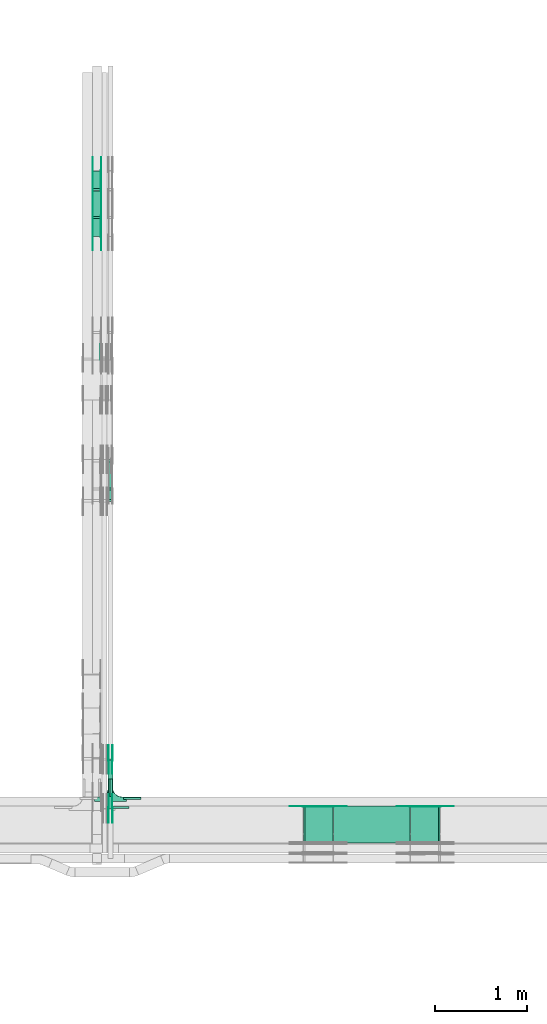
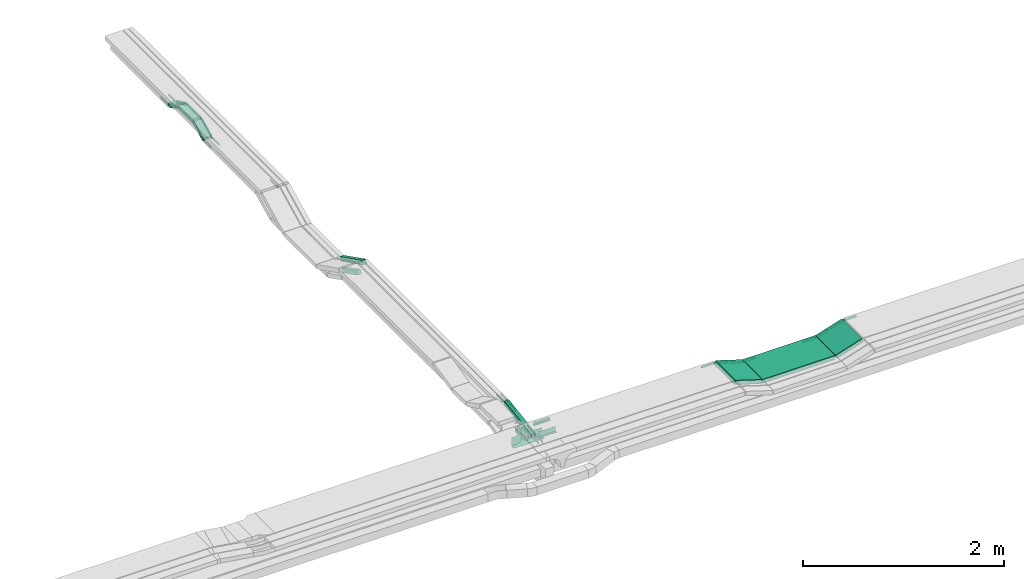
# One storey, part 19 of 27: 38 flow fittings, 9 flow segments.
"""IFC2X3 building model written with IfcOpenShell, lengths in millimetres."""

import ifcopenshell
import ifcopenshell.guid

model = None  # the IFC model being written
_history = None  # IfcOwnerHistory: only IFC2X3 demands one
_inside = {}  # id of a spatial element -> (the spatial element, [elements in it])
_under = {}  # id of a project, library or spatial element -> (it, [spatial elements below it])
_declared = {}  # id of a project -> (the project, [libraries it declares])
_typed = {}  # id of a type object -> (the type object, [elements of that type])
_made_of = {}  # id of a material, layer set ... -> (it, [elements and type objects made of it])


def new_model(schema):
    """Start an empty IFC model of exactly this schema.

    Asked for "IFC4X3", IfcOpenShell would pick the latest addendum, in which some entities
    have other attributes; the version numbers below select the first issue.
    IFC2X3 requires an IfcOwnerHistory on every rooted entity: one is made here for all.
    """
    global model, _history
    if schema == "IFC4X3":
        model = ifcopenshell.file(schema_version=(4, 3, 0, 0))
    else:
        model = ifcopenshell.file(schema=schema)
    _inside.clear()
    _under.clear()
    _declared.clear()
    _typed.clear()
    _made_of.clear()
    _history = None
    if model.schema == "IFC2X3":
        org = make("IfcOrganization", Name="unknown")
        user = make(
            "IfcPersonAndOrganization",
            ThePerson=make("IfcPerson", FamilyName="unknown"),
            TheOrganization=org,
        )
        app = make(
            "IfcApplication",
            ApplicationDeveloper=org,
            Version="unknown",
            ApplicationFullName="unknown",
            ApplicationIdentifier="unknown",
        )
        _history = make(
            "IfcOwnerHistory",
            OwningUser=user,
            OwningApplication=app,
            ChangeAction="ADDED",
            CreationDate=0,
        )
    return model


def make(cls, **values):
    """One entity of the class cls with the attributes given. An attribute that is None is left unset."""
    return model.create_entity(
        cls, **{name: value for name, value in values.items() if value is not None}
    )


def entity(cls, *values):
    """Any entity or typed value of the class cls, its attributes in the order of the schema. None: left unset."""
    e = model.create_entity(cls)
    for i, value in enumerate(values):
        if value is not None:
            e[i] = value
    return e


def rooted(cls, **values):
    """An entity with a GlobalId (a new one), such as an element, a storey or a relation."""
    return make(cls, GlobalId=ifcopenshell.guid.new(), OwnerHistory=_history, **values)


def si_unit(unit_type, name, prefix=None):
    """IfcSIUnit, for example si_unit("LENGTHUNIT", "METRE", prefix="MILLI")."""
    return make("IfcSIUnit", UnitType=unit_type, Prefix=prefix, Name=name)


def converted_unit(unit_type, name, factor, base, dimensions=None, offset=None):
    """IfcConversionBasedUnit, such as the inch: factor (a typed value) times the base unit."""
    return make(
        "IfcConversionBasedUnit"
        if offset is None
        else "IfcConversionBasedUnitWithOffset",
        ConversionOffset=offset,
        Dimensions=None
        if dimensions is None
        else entity("IfcDimensionalExponents", *dimensions),
        UnitType=unit_type,
        Name=name,
        ConversionFactor=make(
            "IfcMeasureWithUnit", ValueComponent=factor, UnitComponent=base
        ),
    )


def derived_unit(unit_type, elements):
    """IfcDerivedUnit: a product of units, each with its exponent."""
    return make(
        "IfcDerivedUnit",
        Elements=[
            make("IfcDerivedUnitElement", Unit=unit, Exponent=power)
            for unit, power in elements
        ],
        UnitType=unit_type,
    )


def assignment(units):
    """IfcUnitAssignment: the units of a project."""
    return None if units is None else make("IfcUnitAssignment", Units=units)


def point(xyz):
    """IfcCartesianPoint."""
    return None if xyz is None else make("IfcCartesianPoint", Coordinates=xyz)


def direction(xyz):
    """IfcDirection."""
    return None if xyz is None else make("IfcDirection", DirectionRatios=xyz)


def frame(location, z_axis=None, x_axis=None):
    """IfcAxis2Placement3D, a coordinate frame: its origin and axes. An axis left out is left unset."""
    return make(
        "IfcAxis2Placement3D",
        Location=point(location),
        Axis=direction(z_axis),
        RefDirection=direction(x_axis),
    )


def frame_2d(location, x_axis=None):
    """IfcAxis2Placement2D, a coordinate frame in the plane: its origin and x axis."""
    return make(
        "IfcAxis2Placement2D", Location=point(location), RefDirection=direction(x_axis)
    )


def origin():
    """The frame at (0, 0, 0) with its axes left unset."""
    return frame((0.0, 0.0, 0.0))


def origin_2d_with_axis():
    """The frame at (0, 0) in the plane with the x axis (1, 0) written out."""
    return frame_2d((0.0, 0.0), x_axis=(1.0, 0.0))


def place(relative_to, where):
    """IfcLocalPlacement: puts the frame where relative to a parent placement (None: the world)."""
    return make(
        "IfcLocalPlacement", PlacementRelTo=relative_to, RelativePlacement=where
    )


def context(
    kind, dimensions, precision=None, world=None, true_north=None, identifier=None
):
    """IfcGeometricRepresentationContext, for example the 3D "Model" context."""
    return make(
        "IfcGeometricRepresentationContext",
        ContextIdentifier=identifier,
        ContextType=kind,
        CoordinateSpaceDimension=dimensions,
        Precision=precision,
        WorldCoordinateSystem=world,
        TrueNorth=true_north,
    )


def subcontext(parent, identifier, kind, view, scale=None):
    """IfcGeometricRepresentationSubContext, for example "Body" below "Model"."""
    return make(
        "IfcGeometricRepresentationSubContext",
        ContextIdentifier=identifier,
        ContextType=kind,
        ParentContext=parent,
        TargetScale=scale,
        TargetView=view,
    )


def project(units=None, contexts=None):
    """IfcProject with its units and contexts."""
    return rooted(
        "IfcProject",
        Name="project",
        RepresentationContexts=contexts,
        UnitsInContext=assignment(units),
    )


def spatial(cls, under=None, at=None, **own):
    """A site, building, storey or space (cls), placed at a placement, below another one or the project."""
    s = rooted(cls, ObjectPlacement=at, **own)
    if under is not None:
        _under.setdefault(under.id(), (under, []))[1].append(s)
    return s


def polyline(points):
    """IfcPolyline through the points."""
    return make("IfcPolyline", Points=[point(p) for p in points])


def circle_curve(where, radius):
    """IfcCircle in the frame where."""
    return make("IfcCircle", Position=where, Radius=radius)


def parameter(value):
    """IfcParameterValue: where a trimmed curve begins or ends, as a parameter of its basis curve."""
    return model.create_entity("IfcParameterValue", value)


def trimmed(basis, trim1, trim2, sense, master):
    """IfcTrimmedCurve: the piece of a basis curve between two trims."""
    return make(
        "IfcTrimmedCurve",
        BasisCurve=basis,
        Trim1=trim1,
        Trim2=trim2,
        SenseAgreement=sense,
        MasterRepresentation=master,
    )


def segment(curve, same_sense, transition):
    """IfcCompositeCurveSegment."""
    return make(
        "IfcCompositeCurveSegment",
        Transition=transition,
        SameSense=same_sense,
        ParentCurve=curve,
    )


def composite_curve(segments, self_intersect=None):
    """IfcCompositeCurve: segments joined end to end."""
    return make("IfcCompositeCurve", Segments=segments, SelfIntersect=self_intersect)


def profile(cls, at=None, kind="AREA", **sizes):
    """A parametric profile (cls). Its sizes go by their IFC names, for example OverallWidth=200.0."""
    return make(cls, ProfileType=kind, Position=at, **sizes)


def rectangle(**sizes):
    """IfcRectangleProfileDef."""
    return profile("IfcRectangleProfileDef", **sizes)


def outline(outer, holes=None, kind="AREA"):
    """IfcArbitraryClosedProfileDef: a profile drawn as a closed curve; with holes, ...WithVoids."""
    if holes is None:
        return make("IfcArbitraryClosedProfileDef", ProfileType=kind, OuterCurve=outer)
    return make(
        "IfcArbitraryProfileDefWithVoids",
        ProfileType=kind,
        OuterCurve=outer,
        InnerCurves=holes,
    )


def extrude(swept, where, along, depth):
    """IfcExtrudedAreaSolid: the profile swept, set in the frame where, extruded along a direction by depth."""
    return make(
        "IfcExtrudedAreaSolid",
        SweptArea=swept,
        Position=where,
        ExtrudedDirection=direction(along),
        Depth=depth,
    )


def faces_of(points, faces, orient=None, outer=None):
    """IfcFace entities. A face is a list of loops; a loop is a list of indices into points, from 0.

    orient and outer hold one flag for each loop. By default every Orientation is true, the
    first loop of a face is its IfcFaceOuterBound and the others are IfcFaceBound.
    """
    made = []
    for i, loops in enumerate(faces):
        bounds = []
        for j, loop in enumerate(loops):
            is_outer = j == 0 if outer is None else outer[i][j]
            bounds.append(
                make(
                    "IfcFaceOuterBound" if is_outer else "IfcFaceBound",
                    Bound=make("IfcPolyLoop", Polygon=[points[k] for k in loop]),
                    Orientation=True if orient is None else orient[i][j],
                )
            )
        made.append(make("IfcFace", Bounds=bounds))
    return made


def faceted_brep(points, faces, orient=None, outer=None, voids=None):
    """IfcFacetedBrep: a solid bounded by flat faces; with voids (closed shells), ...WithVoids."""
    shared = [point(p) for p in points]
    hull = make("IfcClosedShell", CfsFaces=faces_of(shared, faces, orient, outer))
    if voids is None:
        return make("IfcFacetedBrep", Outer=hull)
    return make(
        "IfcFacetedBrepWithVoids",
        Outer=hull,
        Voids=[
            make(cls, CfsFaces=faces_of(shared, fs, o, b)) for cls, fs, o, b in voids
        ],
    )


def shape(context_of_items, identifier, shape_type, items):
    """IfcShapeRepresentation: the items that make up one representation, for example the "Body"."""
    return make(
        "IfcShapeRepresentation",
        ContextOfItems=context_of_items,
        RepresentationIdentifier=identifier,
        RepresentationType=shape_type,
        Items=items,
    )


def source(mapping_origin, context_of_items, identifier, shape_type, items):
    """IfcRepresentationMap: a shape defined once, which mapped items show again and again."""
    return make(
        "IfcRepresentationMap",
        MappingOrigin=mapping_origin,
        MappedRepresentation=shape(context_of_items, identifier, shape_type, items),
    )


def transform(
    local_origin,
    x_axis=None,
    y_axis=None,
    z_axis=None,
    scale=None,
    scale2=None,
    scale3=None,
    uniform=True,
):
    """IfcCartesianTransformationOperator3D, or its non-uniform kind. x_axis, y_axis, z_axis: its Axis1, 2, 3."""
    if uniform:
        return make(
            "IfcCartesianTransformationOperator3D",
            Axis1=direction(x_axis),
            Axis2=direction(y_axis),
            LocalOrigin=point(local_origin),
            Scale=scale,
            Axis3=direction(z_axis),
        )
    return make(
        "IfcCartesianTransformationOperator3DnonUniform",
        Axis1=direction(x_axis),
        Axis2=direction(y_axis),
        LocalOrigin=point(local_origin),
        Scale=scale,
        Axis3=direction(z_axis),
        Scale2=scale2,
        Scale3=scale3,
    )


def mapped(mapping_source, mapping_target):
    """IfcMappedItem: shows the shape of a source again, moved by a transform."""
    return make(
        "IfcMappedItem", MappingSource=mapping_source, MappingTarget=mapping_target
    )


def material(Name=None, Category=None):
    """IfcMaterial."""
    return make("IfcMaterial", Name=Name, Category=Category)


def made_of(thing, what):
    """Note that an element or type object is made of a material, layer set ...; save() writes the relation."""
    if what is not None:
        _made_of.setdefault(what.id(), (what, []))[1].append(thing)
    return thing


def type_object(cls, material=None, **own):
    """A type object (cls), such as IfcWallType, which elements share."""
    return made_of(rooted(cls, **own), material)


def type_shapes(of_type, sources):
    """Give a type object the sources (RepresentationMaps) that its elements show as mapped items."""
    of_type.RepresentationMaps = sources


def element(
    cls,
    number,
    at=None,
    inside=None,
    cuts=None,
    type_object=None,
    material=None,
    context=None,
    identifier="Body",
    shape_type=None,
    held_by="IfcProductDefinitionShape",
    body=None,
    shapes=None,
    **own,
):
    """One element of the class cls, such as IfcWall. Its Tag is "e" and its number.

    at: its placement. inside: the storey or other place that contains it. cuts: it is an
    opening in that element (IfcRelVoidsElement). A single representation is given by context,
    identifier, shape_type and body (its items); several are given by shapes. held_by: the class
    of the entity that holds the representations. save() writes the other relations.
    """
    e = rooted(cls, Tag="e%d" % number, ObjectPlacement=at, **own)
    if body is not None:
        shapes = [shape(context, identifier, shape_type, body)]
    if shapes is not None:
        e.Representation = make(held_by, Representations=shapes)
    if inside is not None:
        _inside.setdefault(inside.id(), (inside, []))[1].append(e)
    if cuts is not None:
        rooted(
            "IfcRelVoidsElement", RelatingBuildingElement=cuts, RelatedOpeningElement=e
        )
    if type_object is not None:
        _typed.setdefault(type_object.id(), (type_object, []))[1].append(e)
    return made_of(e, material)


def aggregate(whole, parts):
    """IfcRelAggregates: a whole, such as a stair, and the parts it consists of."""
    return rooted("IfcRelAggregates", RelatingObject=whole, RelatedObjects=parts)


def save(model, path):
    """Write the relations noted so far, then the file.

    IfcRelAggregates (storeys below a building ...), IfcRelContainedInSpatialStructure (elements
    in a storey), IfcRelDefinesByType, IfcRelAssociatesMaterial and IfcRelDeclares: one each for
    every whole, place, type object, material and project.
    """
    for whole, parts in _under.values():
        aggregate(whole, parts)
    for where, things in _inside.values():
        rooted(
            "IfcRelContainedInSpatialStructure",
            RelatedElements=things,
            RelatingStructure=where,
        )
    for kind, things in _typed.values():
        rooted("IfcRelDefinesByType", RelatedObjects=things, RelatingType=kind)
    for what, things in _made_of.values():
        rooted("IfcRelAssociatesMaterial", RelatedObjects=things, RelatingMaterial=what)
    for by, libraries in _declared.values():
        rooted("IfcRelDeclares", RelatingContext=by, RelatedDefinitions=libraries)
    model.write(path)


model = new_model("IFC2X3")

# Units and contexts
model_context = context("Model", 3, precision=0.01, world=origin(), true_north=direction((6.12303176911189e-17, 1.0)))
body_context = subcontext(model_context, "Body", "Model", "MODEL_VIEW")
ifc_project = project(units=[si_unit("LENGTHUNIT", "METRE", prefix="MILLI"), si_unit("AREAUNIT", "SQUARE_METRE"), si_unit("VOLUMEUNIT", "CUBIC_METRE"), converted_unit("PLANEANGLEUNIT", "DEGREE", entity("IfcRatioMeasure", 0.0174532925199433), si_unit("PLANEANGLEUNIT", "RADIAN"), dimensions=[0, 0, 0, 0, 0, 0, 0]), si_unit("MASSUNIT", "GRAM", prefix="KILO"), derived_unit("MASSDENSITYUNIT", [(si_unit("MASSUNIT", "GRAM", prefix="KILO"), 1), (si_unit("LENGTHUNIT", "METRE"), -3)]), derived_unit("MOMENTOFINERTIAUNIT", [(si_unit("LENGTHUNIT", "METRE"), 4)]), si_unit("TIMEUNIT", "SECOND"), si_unit("FREQUENCYUNIT", "HERTZ"), si_unit("THERMODYNAMICTEMPERATUREUNIT", "DEGREE_CELSIUS"), derived_unit("THERMALTRANSMITTANCEUNIT", [(si_unit("MASSUNIT", "GRAM", prefix="KILO"), 1), (si_unit("THERMODYNAMICTEMPERATUREUNIT", "KELVIN"), -1), (si_unit("TIMEUNIT", "SECOND"), -3)]), derived_unit("VOLUMETRICFLOWRATEUNIT", [(si_unit("LENGTHUNIT", "METRE"), 3), (si_unit("TIMEUNIT", "SECOND"), -1)]), derived_unit("MASSFLOWRATEUNIT", [(si_unit("MASSUNIT", "GRAM", prefix="KILO"), 1), (si_unit("TIMEUNIT", "SECOND"), -1)]), derived_unit("ROTATIONALFREQUENCYUNIT", [(si_unit("TIMEUNIT", "SECOND"), -1)]), si_unit("ELECTRICCURRENTUNIT", "AMPERE"), si_unit("ELECTRICVOLTAGEUNIT", "VOLT"), si_unit("POWERUNIT", "WATT"), si_unit("FORCEUNIT", "NEWTON", prefix="KILO"), si_unit("ILLUMINANCEUNIT", "LUX"), si_unit("LUMINOUSFLUXUNIT", "LUMEN"), si_unit("LUMINOUSINTENSITYUNIT", "CANDELA"), derived_unit("USERDEFINED", [(si_unit("MASSUNIT", "GRAM", prefix="KILO"), -1), (si_unit("LENGTHUNIT", "METRE"), -2), (si_unit("TIMEUNIT", "SECOND"), 3), (si_unit("LUMINOUSFLUXUNIT", "LUMEN"), 1)]), derived_unit("LINEARVELOCITYUNIT", [(si_unit("LENGTHUNIT", "METRE"), 1), (si_unit("TIMEUNIT", "SECOND"), -1)]), si_unit("PRESSUREUNIT", "PASCAL"), derived_unit("USERDEFINED", [(si_unit("LENGTHUNIT", "METRE"), -2), (si_unit("MASSUNIT", "GRAM", prefix="KILO"), 1), (si_unit("TIMEUNIT", "SECOND"), -2)]), derived_unit("LINEARFORCEUNIT", [(si_unit("MASSUNIT", "GRAM", prefix="KILO"), 1), (si_unit("LENGTHUNIT", "METRE"), 1), (si_unit("TIMEUNIT", "SECOND"), -2), (si_unit("LENGTHUNIT", "METRE"), -1)]), derived_unit("PLANARFORCEUNIT", [(si_unit("MASSUNIT", "GRAM", prefix="KILO"), 1), (si_unit("LENGTHUNIT", "METRE"), 1), (si_unit("TIMEUNIT", "SECOND"), -2), (si_unit("LENGTHUNIT", "METRE"), -2)])], contexts=[model_context])

# Site, building, storey
site_placement = place(None, origin())
site = spatial("IfcSite", under=ifc_project, at=site_placement, CompositionType="ELEMENT")
building_placement = place(site_placement, origin())
building = spatial("IfcBuilding", under=site, at=building_placement, CompositionType="ELEMENT")
storey_placement = place(building_placement, origin())
storey = spatial("IfcBuildingStorey", under=building, at=storey_placement, CompositionType="ELEMENT", Elevation=0.0)

# Flow segments
cable_carrier_segment_type = type_object("IfcCableCarrierSegmentType", PredefinedType="CABLETRAYSEGMENT")
flow_segment_1_placement = place(storey_placement, frame((47019.82, 8891.7, 2720.75)))
element("IfcFlowSegment", 1, at=flow_segment_1_placement, inside=storey, type_object=cable_carrier_segment_type, context=body_context, shape_type="SweptSolid", body=[
    extrude(rectangle(XDim=50.0000000000005, YDim=533.151523501238, at=frame_2d((0.0, 0.0), x_axis=(0.0, 1.0))), frame((0.0, 267.34, 64.25), z_axis=(1.0, 0.0, 0.0), x_axis=(0.0, -0.988943608507252, -0.148292073937398)), (0.0, 0.0, 1.0), 50.000000000006),
])
flow_segment_2_placement = place(storey_placement, frame((49465.91, 8520.0, 2750.0)))
element("IfcFlowSegment", 2, at=flow_segment_2_placement, inside=storey, type_object=cable_carrier_segment_type, context=body_context, shape_type="SweptSolid", body=[
    extrude(rectangle(XDim=834.526531103356, YDim=400.0, at=origin_2d_with_axis()), frame((417.26, 200.0, 0.0), z_axis=(0.0, 0.0, 1.0), x_axis=(-1.0, 0.0, 0.0)), (0.0, 0.0, 1.0), 49.9999999999995),
])
flow_segment_3_placement = place(storey_placement, frame((47019.82, 12350.31, 2456.23)))
element("IfcFlowSegment", 3, at=flow_segment_3_placement, inside=storey, type_object=cable_carrier_segment_type, context=body_context, shape_type="SweptSolid", body=[
    extrude(rectangle(XDim=50.0000000000007, YDim=317.472558766534, at=frame_2d((0.0, 0.0), x_axis=(0.0, 1.0))), frame((0.0, 153.0, 93.77), z_axis=(1.0, 0.0, 0.0), x_axis=(0.0, 0.892980854208935, -0.450094650064052)), (0.0, 0.0, 1.0), 50.000000000006),
])
flow_segment_4_placement = place(storey_placement, frame((47012.18, 12227.8, 2581.18)))
element("IfcFlowSegment", 4, at=flow_segment_4_placement, inside=storey, type_object=cable_carrier_segment_type, context=body_context, shape_type="SweptSolid", body=[
    extrude(rectangle(XDim=50.0000000000015, YDim=484.209321850101, at=frame_2d((0.0, 0.0), x_axis=(0.0, 1.0))), frame((0.0, 227.45, 131.29), z_axis=(1.0, 0.0, 0.0), x_axis=(0.0, 0.892980854206702, -0.450094650068481)), (0.0, 0.0, 1.0), 50.000000000006),
])
flow_segment_5_placement = place(storey_placement, frame((46847.77, 15325.71, 2700.0)))
element("IfcFlowSegment", 5, at=flow_segment_5_placement, inside=storey, type_object=cable_carrier_segment_type, context=body_context, shape_type="SweptSolid", body=[
    extrude(rectangle(XDim=276.67146144988, YDim=99.9999999999946, at=origin_2d_with_axis()), frame((50.0, 138.34, 0.0), z_axis=(0.0, 0.0, 1.0), x_axis=(0.0, 1.0, 0.0)), (0.0, 0.0, 1.0), 49.9999999999995),
])
flow_segment_6_placement = place(storey_placement, frame((46847.77, 15108.94, 2605.9)))
element("IfcFlowSegment", 6, at=flow_segment_6_placement, inside=storey, type_object=cable_carrier_segment_type, context=body_context, shape_type="SweptSolid", body=[
    extrude(rectangle(XDim=50.0000000000002, YDim=212.726848185128, at=frame_2d((0.0, 0.0), x_axis=(0.0, 1.0))), frame((0.0, 106.56, 69.1), z_axis=(1.0, 0.0, 0.0), x_axis=(0.0, -0.89879404629905, -0.438371146789316)), (0.0, 0.0, 1.0), 99.9999999999946),
])
flow_segment_7_placement = place(storey_placement, frame((46847.77, 15606.03, 2605.9)))
element("IfcFlowSegment", 7, at=flow_segment_7_placement, inside=storey, type_object=cable_carrier_segment_type, context=body_context, shape_type="SweptSolid", body=[
    extrude(rectangle(XDim=50.0000000000002, YDim=212.726848185074, at=frame_2d((0.0, 0.0), x_axis=(0.0, 1.0))), frame((0.0, 106.56, 69.1), z_axis=(1.0, 0.0, 0.0), x_axis=(0.0, 0.898794046298997, -0.438371146789427)), (0.0, 0.0, 1.0), 99.9999999999945),
])
flow_segment_8_placement = place(storey_placement, frame((50303.6, 8520.0, 2752.81)))
element("IfcFlowSegment", 8, at=flow_segment_8_placement, inside=storey, type_object=cable_carrier_segment_type, context=body_context, shape_type="SweptSolid", body=[
    extrude(rectangle(XDim=49.9999999999976, YDim=320.899186882727, at=frame_2d((0.0, 0.0), x_axis=(0.0, 1.0))), frame((160.52, 0.0, 72.19), z_axis=(0.0, 1.0, 0.0), x_axis=(-0.95351533837897, 0.0, -0.30134448638732)), (0.0, 0.0, 1.0), 400.0),
])
flow_segment_9_placement = place(storey_placement, frame((49141.7, 8520.0, 2752.81)))
element("IfcFlowSegment", 9, at=flow_segment_9_placement, inside=storey, type_object=cable_carrier_segment_type, context=body_context, shape_type="SweptSolid", body=[
    extrude(rectangle(XDim=50.0000000000033, YDim=320.89918688297, at=frame_2d((0.0, 0.0), x_axis=(0.0, 1.0))), frame((160.52, 0.0, 72.19), z_axis=(0.0, 1.0, 0.0), x_axis=(0.953515338379031, 0.0, -0.301344486387127)), (0.0, 0.0, 1.0), 400.0),
])

# Flow fittings
ifc_material_1 = material()
cable_carrier_fitting_type_1 = type_object("IfcCableCarrierFittingType", PredefinedType="NOTDEFINED", material=ifc_material_1)
shared_shape_1 = source(origin(), body_context, "Body", "SweptSolid", [
    extrude(outline(polyline([(-9.17, -21.5), (15.83, -21.5), (15.83, -19.0), (-6.67, -19.0), (-6.67, 40.5), (-9.17, 40.5), (-9.17, -21.5)])), frame((-95.0, 9.17, -26.0), z_axis=(1.0, 0.0, 0.0), x_axis=(0.0, 1.0, 0.0)), (0.0, 0.0, 1.0), 190.0),
])
type_shapes(cable_carrier_fitting_type_1, [shared_shape_1])
flow_fitting_1_placement = place(storey_placement, frame((47279.82, 9017.67, 2650.0), z_axis=(0.0, 0.0, 1.0), x_axis=(-1.0, 0.0, 0.0)))
element("IfcFlowFitting", 10, at=flow_fitting_1_placement, inside=storey, type_object=cable_carrier_fitting_type_1, material=ifc_material_1, context=body_context, shape_type="MappedRepresentation", body=[
    mapped(shared_shape_1, transform((0.0, 0.0, 0.0), scale=1.0)),
])
cable_carrier_fitting_type_2 = type_object("IfcCableCarrierFittingType", PredefinedType="NOTDEFINED", material=ifc_material_1)
type_shapes(cable_carrier_fitting_type_2, [shared_shape_1])
for number, where, z_axis, x_axis in (
    (11, (47022.32, 9120.17, 2650.0), (0.0, 0.0, 1.0), (0.0, -1.0, 0.0)),
    (12, (47067.32, 9120.17, 2650.0), (0.0, 0.0, 1.0), (0.0, 1.0, 0.0)),
):
    element("IfcFlowFitting", number, at=place(storey_placement, frame(where, z_axis=z_axis, x_axis=x_axis)), inside=storey, type_object=cable_carrier_fitting_type_2, material=ifc_material_1, context=body_context, shape_type="MappedRepresentation", body=[
        mapped(shared_shape_1, transform((0.0, 0.0, 0.0), scale=1.0)),
    ])
cable_carrier_fitting_type_3 = type_object("IfcCableCarrierFittingType", PredefinedType="NOTDEFINED", material=ifc_material_1)
shared_shape_2 = source(origin(), body_context, "Body", "SweptSolid", [
    extrude(outline(polyline([(-9.17, -11.5), (15.83, -11.5), (15.83, -9.0), (-6.67, -9.0), (-6.67, 20.5), (-9.17, 20.5), (-9.17, -11.5)])), frame((-95.0, 9.17, -11.0), z_axis=(1.0, 0.0, 0.0), x_axis=(0.0, 1.0, 0.0)), (0.0, 0.0, 1.0), 190.0),
])
type_shapes(cable_carrier_fitting_type_3, [shared_shape_2])
flow_fitting_2_placement = place(storey_placement, frame((47152.18, 8917.5, 2875.0), z_axis=(0.0, 0.0, 1.0), x_axis=(-1.0, 0.0, 0.0)))
element("IfcFlowFitting", 13, at=flow_fitting_2_placement, inside=storey, type_object=cable_carrier_fitting_type_3, material=ifc_material_1, context=body_context, shape_type="MappedRepresentation", body=[
    mapped(shared_shape_2, transform((0.0, 0.0, 0.0), scale=1.0)),
])
cable_carrier_fitting_type_4 = type_object("IfcCableCarrierFittingType", PredefinedType="NOTDEFINED", material=ifc_material_1)
shared_shape_3 = source(origin(), body_context, "Body", "Brep", [
    faceted_brep([(1.0, 197.5, 50.0), (1.0, 197.5, -47.5), (1.0, -200.0, -47.5), (1.0, -200.0, -50.0), (1.0, 200.0, -50.0), (1.0, 200.0, 50.0), (-1.0, 197.5, 50.0), (-1.0, 200.0, 50.0), (-1.0, 200.0, -50.0), (-1.0, -200.0, -50.0), (-1.0, -200.0, -47.5), (-1.0, 197.5, -47.5)], [[[0, 1, 2, 3, 4, 5]], [[6, 7, 8, 9, 10, 11]], [[1, 0, 6, 11]], [[2, 1, 11, 10]], [[3, 2, 10, 9]], [[4, 3, 9, 8]], [[5, 4, 8, 7]], [[0, 5, 7, 6]]]),
    faceted_brep([(22.5, -300.0, 50.0), (22.5, -350.0, 50.0), (25.0, -350.0, 50.0), (25.0, -300.0, 50.0), (28.41, -274.12, 50.0), (38.4, -250.0, 50.0), (54.29, -229.29, 50.0), (75.0, -213.4, 50.0), (99.12, -203.41, 50.0), (125.0, -200.0, 50.0), (175.0, -200.0, 50.0), (175.0, -197.5, 50.0), (125.0, -197.5, 50.0), (98.47, -200.99, 50.0), (73.75, -211.23, 50.0), (52.52, -227.52, 50.0), (36.23, -248.75, 50.0), (25.99, -273.47, 50.0), (-99.12, -203.41, 50.0), (-75.0, -213.4, 50.0), (-54.29, -229.29, 50.0), (-38.4, -250.0, 50.0), (-28.41, -274.12, 50.0), (-25.0, -300.0, 50.0), (-25.0, -350.0, 50.0), (-22.5, -350.0, 50.0), (-22.5, -300.0, 50.0), (-25.99, -273.47, 50.0), (-36.23, -248.75, 50.0), (-52.52, -227.52, 50.0), (-73.75, -211.23, 50.0), (-98.47, -200.99, 50.0), (-125.0, -197.5, 50.0), (-175.0, -197.5, 50.0), (-175.0, -200.0, 50.0), (-125.0, -200.0, 50.0), (-99.12, -203.41, -50.0), (-114.21, -201.42, -50.0), (-125.0, -200.0, -50.0), (-125.0, -200.0, -52.5), (-112.06, -201.7, -52.5), (-99.12, -203.41, -52.5), (-75.0, -213.4, -50.0), (-87.06, -208.4, -50.0), (-87.06, -208.4, -52.5), (-75.0, -213.4, -52.5), (-64.64, -221.34, -50.0), (-54.29, -229.29, -50.0), (-64.64, -221.34, -52.5), (-54.29, -229.29, -52.5), (-28.41, -274.12, -50.0), (-33.4, -262.06, -50.0), (-38.4, -250.0, -50.0), (-38.4, -250.0, -52.5), (-33.4, -262.06, -52.5), (-28.41, -274.12, -52.5), (-25.0, -300.0, -50.0), (-26.7, -287.06, -50.0), (-26.42, -289.21, -52.5), (-25.0, -300.0, -52.5), (-46.34, -239.64, -50.0), (-46.34, -239.64, -52.5), (-25.0, -350.0, -52.5), (25.0, -350.0, -52.5), (22.5, -350.0, -50.0), (-22.5, -350.0, -50.0), (-22.5, -300.0, -50.0), (-25.99, -273.47, -50.0), (-36.23, -248.75, -50.0), (-52.52, -227.52, -50.0), (-73.75, -211.23, -50.0), (-98.47, -200.99, -50.0), (-125.0, -197.5, -50.0), (25.0, -300.0, -52.5), (25.0, -300.0, -50.0), (28.41, -274.12, -50.0), (33.4, -262.06, -50.0), (38.4, -250.0, -50.0), (28.41, -274.12, -52.5), (33.4, -262.06, -52.5), (38.4, -250.0, -52.5), (46.34, -239.64, -50.0), (54.29, -229.29, -50.0), (46.34, -239.64, -52.5), (54.29, -229.29, -52.5), (26.42, -289.21, -50.0), (26.7, -287.06, -52.5), (75.0, -213.4, -50.0), (87.06, -208.4, -50.0), (99.12, -203.41, -50.0), (75.0, -213.4, -52.5), (87.06, -208.4, -52.5), (99.12, -203.41, -52.5), (112.06, -201.7, -50.0), (125.0, -200.0, -50.0), (114.21, -201.42, -52.5), (125.0, -200.0, -52.5), (64.64, -221.34, -50.0), (64.64, -221.34, -52.5), (98.47, -200.99, -50.0), (73.75, -211.23, -50.0), (52.52, -227.52, -50.0), (125.0, -197.5, -50.0), (36.23, -248.75, -50.0), (25.99, -273.47, -50.0), (22.5, -300.0, -50.0), (-175.0, -197.5, -50.0), (175.0, -197.5, -50.0), (-175.0, -150.0, -50.0), (-175.0, -150.0, -52.5), (-175.0, -200.0, -52.5), (175.0, -200.0, -52.5), (175.0, -150.0, -52.5), (175.0, -150.0, -50.0)], [[[0, 1, 2, 3, 4, 5, 6, 7, 8, 9, 10, 11, 12, 13, 14, 15, 16, 17]], [[18, 19, 20, 21, 22, 23, 24, 25, 26, 27, 28, 29, 30, 31, 32, 33, 34, 35]], [[18, 35, 36]], [[35, 37, 36]], [[35, 38, 37]], [[37, 38, 39]], [[37, 39, 40]], [[36, 40, 41]], [[37, 40, 36]], [[19, 18, 42]], [[18, 43, 42]], [[18, 36, 43]], [[36, 41, 43]], [[44, 43, 41]], [[43, 44, 42]], [[44, 45, 42]], [[19, 42, 46]], [[19, 46, 47]], [[47, 20, 19]], [[46, 42, 45]], [[46, 45, 48]], [[48, 49, 47]], [[46, 48, 47]], [[22, 21, 50]], [[21, 51, 50]], [[21, 52, 51]], [[52, 53, 51]], [[54, 51, 53]], [[51, 54, 50]], [[54, 55, 50]], [[23, 22, 56]], [[22, 57, 56]], [[22, 50, 57]], [[50, 55, 57]], [[58, 57, 55]], [[58, 59, 56]], [[57, 58, 56]], [[20, 47, 60]], [[20, 60, 52]], [[52, 21, 20]], [[60, 47, 49]], [[60, 49, 61]], [[60, 61, 52]], [[61, 53, 52]], [[24, 23, 56, 59, 62]], [[25, 24, 62, 63, 2, 1, 64, 65]], [[26, 25, 65, 66]], [[27, 67, 68, 28]], [[28, 68, 69, 29]], [[66, 67, 27, 26]], [[30, 70, 71, 31]], [[31, 71, 72, 32]], [[29, 69, 70, 30]], [[3, 2, 63, 73, 74]], [[5, 4, 75]], [[5, 75, 76]], [[5, 76, 77]], [[75, 78, 76]], [[79, 76, 78]], [[76, 79, 77]], [[79, 80, 77]], [[6, 5, 77]], [[6, 77, 81]], [[6, 81, 82]], [[81, 77, 80]], [[81, 80, 83]], [[83, 84, 82]], [[81, 83, 82]], [[74, 4, 3]], [[4, 74, 85]], [[85, 74, 73]], [[85, 73, 86]], [[85, 86, 75]], [[75, 86, 78]], [[4, 85, 75]], [[8, 7, 87]], [[8, 87, 88]], [[8, 88, 89]], [[87, 90, 88]], [[91, 88, 90]], [[88, 91, 89]], [[91, 92, 89]], [[9, 8, 89]], [[9, 89, 93]], [[9, 93, 94]], [[89, 92, 93]], [[95, 93, 92]], [[95, 96, 94]], [[93, 95, 94]], [[7, 82, 97]], [[6, 82, 7]], [[7, 97, 87]], [[97, 82, 84]], [[97, 84, 98]], [[97, 98, 87]], [[98, 90, 87]], [[13, 99, 100, 14]], [[14, 100, 101, 15]], [[102, 99, 13, 12]], [[16, 103, 104, 17]], [[17, 104, 105, 0]], [[15, 101, 103, 16]], [[1, 0, 105, 64]], [[33, 32, 72, 106]], [[12, 11, 107, 102]], [[34, 33, 106, 108, 109, 110]], [[35, 34, 110, 39, 38]], [[10, 9, 94, 96, 111]], [[10, 111, 112, 113, 107, 11]], [[107, 113, 108, 106, 72, 71, 70, 69, 68, 67, 66, 65, 64, 105, 104, 103, 101, 100, 99, 102]], [[110, 109, 112, 111, 96, 95, 92, 91, 90, 98, 84, 83, 80, 79, 78, 86, 73, 63, 62, 59, 58, 55, 54, 53, 61, 49, 48, 45, 44, 41, 40, 39]], [[108, 113, 112, 109]]]),
])
type_shapes(cable_carrier_fitting_type_4, [shared_shape_3])
flow_fitting_3_placement = place(storey_placement, frame((47044.82, 8820.17, 2650.0), z_axis=(0.0, 0.0, 1.0), x_axis=(-1.0, 0.0, 0.0)))
element("IfcFlowFitting", 14, at=flow_fitting_3_placement, inside=storey, type_object=cable_carrier_fitting_type_4, material=ifc_material_1, context=body_context, shape_type="MappedRepresentation", body=[
    mapped(shared_shape_3, transform((0.0, 0.0, 0.0), scale=1.0)),
])
ifc_material_2 = material(Name="G")
cable_carrier_fitting_type_5 = type_object("IfcCableCarrierFittingType", PredefinedType="NOTDEFINED", material=ifc_material_2)
shared_shape_4 = source(origin(), body_context, "Body", "SweptSolid", [
    extrude(outline(composite_curve([segment(trimmed(circle_curve(frame_2d((-44.59, 0.0), x_axis=(1.0, 0.0)), 12.5), [parameter(90.0000000000007)], [parameter(270.0)], True, "PARAMETER"), True, "CONTINUOUS"), segment(polyline([(-44.59, -12.5), (-33.09, -12.5)]), True, "CONTINUOUS"), segment(polyline([(-33.09, -12.5), (-31.23, -14.5)]), True, "CONTINUOUS"), segment(polyline([(-31.23, -14.5), (108.91, -14.5)]), True, "CONTINUOUS"), segment(polyline([(108.91, -14.5), (108.91, 14.5)]), True, "CONTINUOUS"), segment(polyline([(108.91, 14.5), (-31.23, 14.5)]), True, "CONTINUOUS"), segment(polyline([(-31.23, 14.5), (-33.09, 12.5)]), True, "CONTINUOUS"), segment(polyline([(-33.09, 12.5), (-44.59, 12.5)]), True, "CONTINUOUS")], self_intersect=False)), frame((44.59, 0.0, 0.0), z_axis=(0.0, 0.0, -1.0), x_axis=(1.0, 0.0, 0.0)), (0.0, 0.0, -1.0), 2.0),
])
type_shapes(cable_carrier_fitting_type_5, [shared_shape_4])
flow_fitting_4_placement = place(storey_placement, frame((47024.66, 9425.79, 2825.0), z_axis=(-1.0, 0.0, 0.0), x_axis=(0.0, 1.0, 0.0)))
element("IfcFlowFitting", 15, at=flow_fitting_4_placement, inside=storey, type_object=cable_carrier_fitting_type_5, material=ifc_material_2, context=body_context, shape_type="MappedRepresentation", body=[
    mapped(shared_shape_4, transform((0.0, 0.0, 0.0), scale=1.0)),
])
cable_carrier_fitting_type_6 = type_object("IfcCableCarrierFittingType", PredefinedType="NOTDEFINED", material=ifc_material_2)
type_shapes(cable_carrier_fitting_type_6, [shared_shape_4])
flow_fitting_5_placement = place(storey_placement, frame((47063.58, 9425.79, 2825.0), z_axis=(1.0, 0.0, 0.0), x_axis=(0.0, -0.988943608506525, -0.148292073942246)))
element("IfcFlowFitting", 16, at=flow_fitting_5_placement, inside=storey, type_object=cable_carrier_fitting_type_6, material=ifc_material_2, context=body_context, shape_type="MappedRepresentation", body=[
    mapped(shared_shape_4, transform((0.0, 0.0, 0.0), scale=1.0)),
])
flow_fitting_6_placement = place(storey_placement, frame((47024.66, 8892.28, 2745.0), z_axis=(-1.0, 0.0, 0.0), x_axis=(0.0, -1.0, 0.0)))
element("IfcFlowFitting", 17, at=flow_fitting_6_placement, inside=storey, type_object=cable_carrier_fitting_type_5, material=ifc_material_2, context=body_context, shape_type="MappedRepresentation", body=[
    mapped(shared_shape_4, transform((0.0, 0.0, 0.0), scale=1.0)),
])
flow_fitting_7_placement = place(storey_placement, frame((47063.58, 8892.28, 2745.0), z_axis=(1.0, 0.0, 0.0), x_axis=(0.0, 0.988943608506523, 0.148292073942261)))
element("IfcFlowFitting", 18, at=flow_fitting_7_placement, inside=storey, type_object=cable_carrier_fitting_type_6, material=ifc_material_2, context=body_context, shape_type="MappedRepresentation", body=[
    mapped(shared_shape_4, transform((0.0, 0.0, 0.0), scale=1.0)),
])
flow_fitting_8_placement = place(storey_placement, frame((46852.31, 15318.01, 2725.0), z_axis=(-1.0, 0.0, 0.0), x_axis=(0.0, 1.0, 0.0)))
element("IfcFlowFitting", 19, at=flow_fitting_8_placement, inside=storey, type_object=cable_carrier_fitting_type_5, material=ifc_material_2, context=body_context, shape_type="MappedRepresentation", body=[
    mapped(shared_shape_4, transform((0.0, 0.0, 0.0), scale=1.0)),
])
flow_fitting_9_placement = place(storey_placement, frame((46941.23, 15318.01, 2725.0), z_axis=(1.0, 0.0, 0.0), x_axis=(0.0, -0.898794046298952, -0.438371146789519)))
element("IfcFlowFitting", 20, at=flow_fitting_9_placement, inside=storey, type_object=cable_carrier_fitting_type_6, material=ifc_material_2, context=body_context, shape_type="MappedRepresentation", body=[
    mapped(shared_shape_4, transform((0.0, 0.0, 0.0), scale=1.0)),
])
flow_fitting_10_placement = place(storey_placement, frame((46943.23, 15610.07, 2725.0), z_axis=(1.0, 0.0, 0.0), x_axis=(0.0, -1.0, 0.0)))
element("IfcFlowFitting", 21, at=flow_fitting_10_placement, inside=storey, type_object=cable_carrier_fitting_type_5, material=ifc_material_2, context=body_context, shape_type="MappedRepresentation", body=[
    mapped(shared_shape_4, transform((0.0, 0.0, 0.0), scale=1.0)),
])
flow_fitting_11_placement = place(storey_placement, frame((46854.31, 15610.07, 2725.0), z_axis=(-1.0, 0.0, 0.0), x_axis=(0.0, 0.898794046298952, -0.438371146789519)))
element("IfcFlowFitting", 22, at=flow_fitting_11_placement, inside=storey, type_object=cable_carrier_fitting_type_6, material=ifc_material_2, context=body_context, shape_type="MappedRepresentation", body=[
    mapped(shared_shape_4, transform((0.0, 0.0, 0.0), scale=1.0)),
])
flow_fitting_12_placement = place(storey_placement, frame((46943.23, 15815.1, 2625.0), z_axis=(1.0, 0.0, 0.0), x_axis=(0.0, 1.0, 0.0)))
element("IfcFlowFitting", 23, at=flow_fitting_12_placement, inside=storey, type_object=cable_carrier_fitting_type_5, material=ifc_material_2, context=body_context, shape_type="MappedRepresentation", body=[
    mapped(shared_shape_4, transform((0.0, 0.0, 0.0), scale=1.0)),
])
flow_fitting_13_placement = place(storey_placement, frame((46854.31, 15815.1, 2625.0), z_axis=(-1.0, 0.0, 0.0), x_axis=(0.0, -0.898794046299012, 0.438371146789395)))
element("IfcFlowFitting", 24, at=flow_fitting_13_placement, inside=storey, type_object=cable_carrier_fitting_type_6, material=ifc_material_2, context=body_context, shape_type="MappedRepresentation", body=[
    mapped(shared_shape_4, transform((0.0, 0.0, 0.0), scale=1.0)),
])
flow_fitting_14_placement = place(storey_placement, frame((46852.31, 15112.98, 2625.0), z_axis=(-1.0, 0.0, 0.0), x_axis=(0.0, -1.0, 0.0)))
element("IfcFlowFitting", 25, at=flow_fitting_14_placement, inside=storey, type_object=cable_carrier_fitting_type_5, material=ifc_material_2, context=body_context, shape_type="MappedRepresentation", body=[
    mapped(shared_shape_4, transform((0.0, 0.0, 0.0), scale=1.0)),
])
flow_fitting_15_placement = place(storey_placement, frame((46941.23, 15112.98, 2625.0), z_axis=(1.0, 0.0, 0.0), x_axis=(0.0, 0.898794046299068, 0.43837114678928)))
element("IfcFlowFitting", 26, at=flow_fitting_15_placement, inside=storey, type_object=cable_carrier_fitting_type_6, material=ifc_material_2, context=body_context, shape_type="MappedRepresentation", body=[
    mapped(shared_shape_4, transform((0.0, 0.0, 0.0), scale=1.0)),
])
for number, where, z_axis, x_axis in (
    (27, (50622.33, 8915.46, 2875.0), (0.0, 1.0, 0.0), (1.0, 0.0, 0.0)),
    (28, (50305.91, 8915.46, 2775.0), (0.0, 1.0, 0.0), (-1.0, 0.0, 0.0)),
):
    element("IfcFlowFitting", number, at=place(storey_placement, frame(where, z_axis=z_axis, x_axis=x_axis)), inside=storey, type_object=cable_carrier_fitting_type_5, material=ifc_material_2, context=body_context, shape_type="MappedRepresentation", body=[
        mapped(shared_shape_4, transform((0.0, 0.0, 0.0), scale=1.0)),
    ])
for number, where, z_axis, x_axis in (
    (29, (49460.44, 8913.46, 2775.0), (0.0, 1.0, 0.0), (-0.953515338379008, 0.0, 0.3013444863872)),
    (30, (49144.02, 8913.46, 2875.0), (0.0, 1.0, 0.0), (0.953515338379043, 0.0, -0.301344486387091)),
):
    element("IfcFlowFitting", number, at=place(storey_placement, frame(where, z_axis=z_axis, x_axis=x_axis)), inside=storey, type_object=cable_carrier_fitting_type_6, material=ifc_material_2, context=body_context, shape_type="MappedRepresentation", body=[
        mapped(shared_shape_4, transform((0.0, 0.0, 0.0), scale=1.0)),
    ])
cable_carrier_fitting_type_7 = type_object("IfcCableCarrierFittingType", PredefinedType="NOTDEFINED", material=ifc_material_2)
shared_shape_5 = source(origin(), body_context, "Body", "SweptSolid", [
    extrude(outline(composite_curve([segment(trimmed(circle_curve(frame_2d((-44.59, 0.0), x_axis=(1.0, 0.0)), 12.5), [parameter(90.0000000000007)], [parameter(270.0)], True, "PARAMETER"), True, "CONTINUOUS"), segment(polyline([(-44.59, -12.5), (-33.09, -12.5)]), True, "CONTINUOUS"), segment(polyline([(-33.09, -12.5), (-31.23, -14.5)]), True, "CONTINUOUS"), segment(polyline([(-31.23, -14.5), (108.91, -14.5)]), True, "CONTINUOUS"), segment(polyline([(108.91, -14.5), (108.91, 14.5)]), True, "CONTINUOUS"), segment(polyline([(108.91, 14.5), (-31.23, 14.5)]), True, "CONTINUOUS"), segment(polyline([(-31.23, 14.5), (-33.09, 12.5)]), True, "CONTINUOUS"), segment(polyline([(-33.09, 12.5), (-44.59, 12.5)]), True, "CONTINUOUS")], self_intersect=False)), frame((44.59, 0.0, 0.0)), (0.0, 0.0, 1.0), 2.0),
])
type_shapes(cable_carrier_fitting_type_7, [shared_shape_5])
flow_fitting_16_placement = place(storey_placement, frame((47065.58, 9425.79, 2825.0), z_axis=(1.0, 0.0, 0.0), x_axis=(0.0, 1.0, 0.0)))
element("IfcFlowFitting", 31, at=flow_fitting_16_placement, inside=storey, type_object=cable_carrier_fitting_type_7, material=ifc_material_2, context=body_context, shape_type="MappedRepresentation", body=[
    mapped(shared_shape_5, transform((0.0, 0.0, 0.0), scale=1.0)),
])
cable_carrier_fitting_type_8 = type_object("IfcCableCarrierFittingType", PredefinedType="NOTDEFINED", material=ifc_material_2)
type_shapes(cable_carrier_fitting_type_8, [shared_shape_5])
flow_fitting_17_placement = place(storey_placement, frame((47026.66, 9425.79, 2825.0), z_axis=(-1.0, 0.0, 0.0), x_axis=(0.0, -0.988943608506525, -0.148292073942246)))
element("IfcFlowFitting", 32, at=flow_fitting_17_placement, inside=storey, type_object=cable_carrier_fitting_type_8, material=ifc_material_2, context=body_context, shape_type="MappedRepresentation", body=[
    mapped(shared_shape_5, transform((0.0, 0.0, 0.0), scale=1.0)),
])
flow_fitting_18_placement = place(storey_placement, frame((47065.58, 8892.28, 2745.0), z_axis=(1.0, 0.0, 0.0), x_axis=(0.0, -1.0, 0.0)))
element("IfcFlowFitting", 33, at=flow_fitting_18_placement, inside=storey, type_object=cable_carrier_fitting_type_7, material=ifc_material_2, context=body_context, shape_type="MappedRepresentation", body=[
    mapped(shared_shape_5, transform((0.0, 0.0, 0.0), scale=1.0)),
])
flow_fitting_19_placement = place(storey_placement, frame((47026.66, 8892.28, 2745.0), z_axis=(-1.0, 0.0, 0.0), x_axis=(0.0, 0.988943608506523, 0.148292073942261)))
element("IfcFlowFitting", 34, at=flow_fitting_19_placement, inside=storey, type_object=cable_carrier_fitting_type_8, material=ifc_material_2, context=body_context, shape_type="MappedRepresentation", body=[
    mapped(shared_shape_5, transform((0.0, 0.0, 0.0), scale=1.0)),
])
flow_fitting_20_placement = place(storey_placement, frame((46943.23, 15318.01, 2725.0), z_axis=(1.0, 0.0, 0.0), x_axis=(0.0, 1.0, 0.0)))
element("IfcFlowFitting", 35, at=flow_fitting_20_placement, inside=storey, type_object=cable_carrier_fitting_type_7, material=ifc_material_2, context=body_context, shape_type="MappedRepresentation", body=[
    mapped(shared_shape_5, transform((0.0, 0.0, 0.0), scale=1.0)),
])
flow_fitting_21_placement = place(storey_placement, frame((46854.31, 15318.01, 2725.0), z_axis=(-1.0, 0.0, 0.0), x_axis=(0.0, -0.898794046298952, -0.438371146789519)))
element("IfcFlowFitting", 36, at=flow_fitting_21_placement, inside=storey, type_object=cable_carrier_fitting_type_8, material=ifc_material_2, context=body_context, shape_type="MappedRepresentation", body=[
    mapped(shared_shape_5, transform((0.0, 0.0, 0.0), scale=1.0)),
])
flow_fitting_22_placement = place(storey_placement, frame((46852.31, 15610.07, 2725.0), z_axis=(-1.0, 0.0, 0.0), x_axis=(0.0, -1.0, 0.0)))
element("IfcFlowFitting", 37, at=flow_fitting_22_placement, inside=storey, type_object=cable_carrier_fitting_type_7, material=ifc_material_2, context=body_context, shape_type="MappedRepresentation", body=[
    mapped(shared_shape_5, transform((0.0, 0.0, 0.0), scale=1.0)),
])
flow_fitting_23_placement = place(storey_placement, frame((46941.23, 15610.07, 2725.0), z_axis=(1.0, 0.0, 0.0), x_axis=(0.0, 0.898794046298952, -0.438371146789519)))
element("IfcFlowFitting", 38, at=flow_fitting_23_placement, inside=storey, type_object=cable_carrier_fitting_type_8, material=ifc_material_2, context=body_context, shape_type="MappedRepresentation", body=[
    mapped(shared_shape_5, transform((0.0, 0.0, 0.0), scale=1.0)),
])
flow_fitting_24_placement = place(storey_placement, frame((46852.31, 15815.1, 2625.0), z_axis=(-1.0, 0.0, 0.0), x_axis=(0.0, 1.0, 0.0)))
element("IfcFlowFitting", 39, at=flow_fitting_24_placement, inside=storey, type_object=cable_carrier_fitting_type_7, material=ifc_material_2, context=body_context, shape_type="MappedRepresentation", body=[
    mapped(shared_shape_5, transform((0.0, 0.0, 0.0), scale=1.0)),
])
flow_fitting_25_placement = place(storey_placement, frame((46941.23, 15815.1, 2625.0), z_axis=(1.0, 0.0, 0.0), x_axis=(0.0, -0.898794046299012, 0.438371146789395)))
element("IfcFlowFitting", 40, at=flow_fitting_25_placement, inside=storey, type_object=cable_carrier_fitting_type_8, material=ifc_material_2, context=body_context, shape_type="MappedRepresentation", body=[
    mapped(shared_shape_5, transform((0.0, 0.0, 0.0), scale=1.0)),
])
flow_fitting_26_placement = place(storey_placement, frame((46943.23, 15112.98, 2625.0), z_axis=(1.0, 0.0, 0.0), x_axis=(0.0, -1.0, 0.0)))
element("IfcFlowFitting", 41, at=flow_fitting_26_placement, inside=storey, type_object=cable_carrier_fitting_type_7, material=ifc_material_2, context=body_context, shape_type="MappedRepresentation", body=[
    mapped(shared_shape_5, transform((0.0, 0.0, 0.0), scale=1.0)),
])
for number, where, z_axis, x_axis in (
    (42, (46854.31, 15112.98, 2625.0), (-1.0, 0.0, 0.0), (0.0, 0.898794046299068, 0.43837114678928)),
    (43, (46935.64, 13782.88, 2825.0), (1.0, 0.0, 0.0), (0.0, 1.0, 0.0)),
    (44, (50622.33, 8913.46, 2875.0), (0.0, 1.0, 0.0), (-0.953515338378991, 0.0, -0.301344486387255)),
    (45, (50305.91, 8913.46, 2775.0), (0.0, 1.0, 0.0), (0.953515338378973, 0.0, 0.301344486387313)),
):
    element("IfcFlowFitting", number, at=place(storey_placement, frame(where, z_axis=z_axis, x_axis=x_axis)), inside=storey, type_object=cable_carrier_fitting_type_8, material=ifc_material_2, context=body_context, shape_type="MappedRepresentation", body=[
        mapped(shared_shape_5, transform((0.0, 0.0, 0.0), scale=1.0)),
    ])
for number, where, z_axis, x_axis in (
    (46, (49460.44, 8915.46, 2775.0), (0.0, 1.0, 0.0), (1.0, 0.0, 0.0)),
    (47, (49144.02, 8915.46, 2875.0), (0.0, 1.0, 0.0), (-1.0, 0.0, 0.0)),
):
    element("IfcFlowFitting", number, at=place(storey_placement, frame(where, z_axis=z_axis, x_axis=x_axis)), inside=storey, type_object=cable_carrier_fitting_type_7, material=ifc_material_2, context=body_context, shape_type="MappedRepresentation", body=[
        mapped(shared_shape_5, transform((0.0, 0.0, 0.0), scale=1.0)),
    ])

save(model, "model.ifc")
